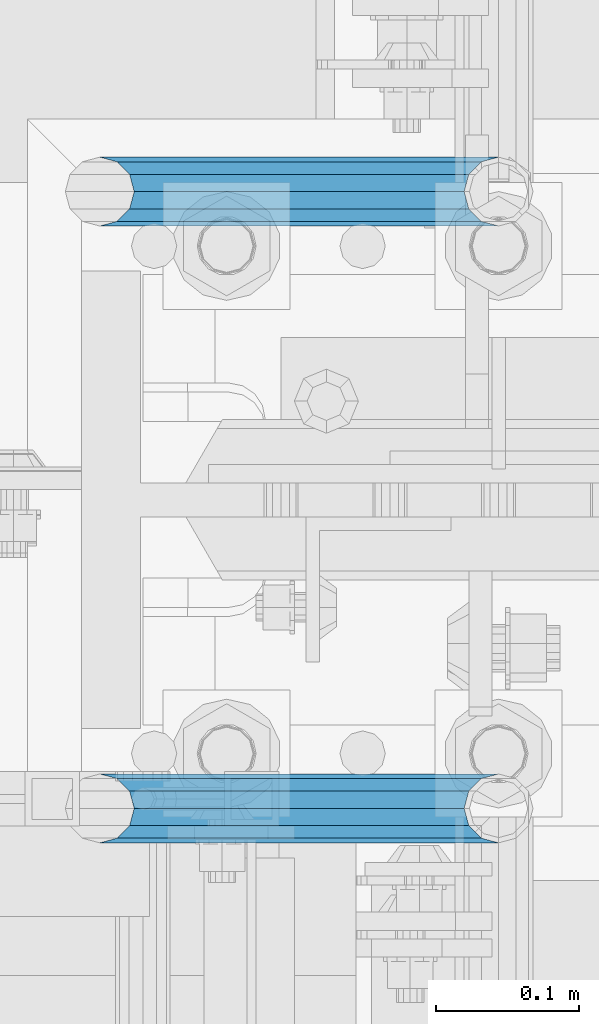
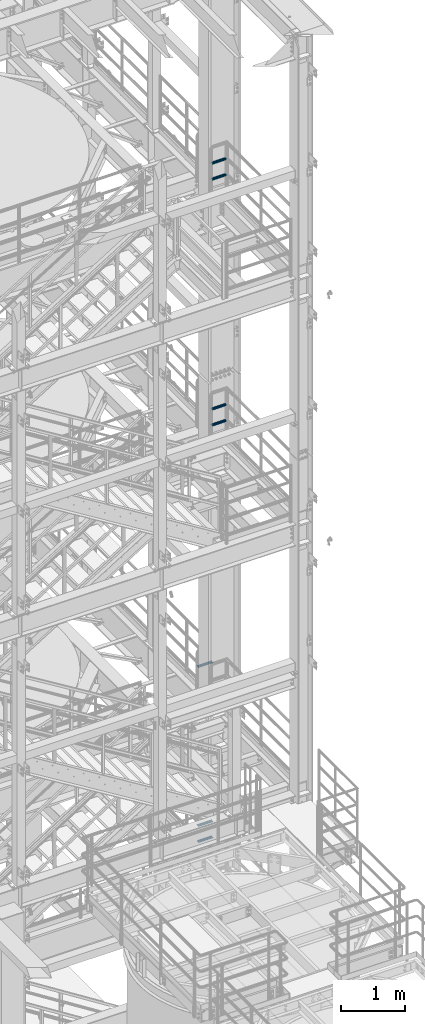
# One storey, part 1209 of 1876: 7 beams, 4 elements without a shape of their own.
"""IFC2X3 building model written with IfcOpenShell, lengths in millimetres."""

from ifc_helpers import new_model, si_unit, frame, origin_with_axes, place, context, subcontext, project, spatial, faceted_brep, material, type_object, element, aggregate, save


model = new_model("IFC2X3")

# Units and contexts
model_context = context("Model", 3, precision=1e-05, world=origin_with_axes())
body_context = subcontext(model_context, "Body", "Model", "MODEL_VIEW")
ifc_project = project(units=[si_unit("LENGTHUNIT", "METRE", prefix="MILLI"), si_unit("AREAUNIT", "SQUARE_METRE"), si_unit("VOLUMEUNIT", "CUBIC_METRE"), si_unit("MASSUNIT", "GRAM", prefix="KILO"), si_unit("TIMEUNIT", "SECOND"), si_unit("PLANEANGLEUNIT", "RADIAN"), si_unit("SOLIDANGLEUNIT", "STERADIAN"), si_unit("THERMODYNAMICTEMPERATUREUNIT", "DEGREE_CELSIUS"), si_unit("LUMINOUSINTENSITYUNIT", "LUMEN")], contexts=[model_context])

# Site, building, storey
site_placement = place(None, origin_with_axes())
site = spatial("IfcSite", under=ifc_project, at=site_placement, CompositionType="ELEMENT")
building_placement = place(site_placement, origin_with_axes())
building = spatial("IfcBuilding", under=site, at=building_placement, Name="Undefined", CompositionType="ELEMENT")
storey_placement = place(building_placement, origin_with_axes())
storey = spatial("IfcBuildingStorey", under=building, at=storey_placement, Name="Undefined", CompositionType="ELEMENT", Elevation=0.0)

# Assembly, beam
assembly_1_placement = place(storey_placement, origin_with_axes())
assembly_1 = element("IfcElementAssembly", 1, at=assembly_1_placement, inside=storey, Name="RAIL", AssemblyPlace="NOTDEFINED", PredefinedType="RIGID_FRAME")
ifc_material = material()
beam_type = type_object("IfcBeamType", Name="PIPE1-1/2SCH40", PredefinedType="NOTDEFINED")
beam_1_placement = place(assembly_1_placement, frame((7620.00000000001, -4356.1, 8924.92500003594), z_axis=(0.0, 0.0, 1.0), x_axis=(-1.0, 0.0, 0.0)))
beam_1 = element("IfcBeam", 2, at=beam_1_placement, type_object=beam_type, material=ifc_material, Name="RAIL", ObjectType="PIPE1-1/2SCH40", context=body_context, shape_type="Brep", body=[
    faceted_brep([(258.502800903171, -12.0650000000005, 20.8971929933177), (258.502800903171, -12.0650000000005, 15.8661214311796), (258.009372465309, -10.2235000000001, 17.7076214311819), (255.26999389649, 0.0, 20.4470000000001), (255.26999389649, 0.0, 24.130000000001), (258.009372465309, 10.2235000000001, 17.7076214311819), (258.502800903171, 12.0650000000005, 15.8661214311796), (258.502800903171, 12.0650000000005, 20.8971929933177), (279.399993896489, 24.1299999999992, 0.0), (267.33499389649, 20.8971929933177, 12.0649999999987), (267.33499389649, 20.8971929933177, -12.0649999999987), (264.145422334351, 17.7076214311801, 10.2235000000001), (266.884800903171, 20.4470000000001, 0.0), (264.145422334351, 17.7076214311801, -10.2235000000001), (258.502800903171, 12.0650000000005, -15.8661214311796), (258.502800903171, 12.0650000000005, -20.8971929933177), (258.009372465309, 10.2235000000001, -17.7076214311819), (255.26999389649, 0.0, -20.4470000000001), (255.26999389649, 0.0, -24.130000000001), (258.502800903171, -12.0650000000005, -15.8661214311796), (258.502800903171, -12.0650000000005, -20.8971929933177), (258.009372465309, -10.2235000000001, -17.7076214311819), (279.399993896489, -24.1299999999992, 0.0), (267.33499389649, -20.8971929933177, -12.0649999999987), (267.33499389649, -20.8971929933177, 12.0649999999987), (264.145422334351, -17.7076214311801, -10.2235000000001), (266.884800903171, -20.4470000000001, 0.0), (264.145422334351, -17.7076214311801, 10.2235000000001), (12.0650000000064, -20.8971929933177, -12.0649999999987), (20.8971929933249, -12.0650000000005, -20.8971929933177), (0.0, 24.1299999999992, 0.0), (12.0650000000064, 20.8971929933177, -12.0649999999987), (12.0650000000064, 20.8971929933177, 12.0649999999987), (20.8971929933249, 12.0650000000005, 20.8971929933177), (24.1300000000064, 0.0, 24.130000000001), (20.8971929933249, 12.0650000000005, -20.8971929933177), (24.1300000000063, 0.0, -24.130000000001), (24.1300000000063, 0.0, -20.4470000000001), (20.8971929933249, -12.0650000000005, -15.8661214311796), (21.3906214311868, -10.2235000000001, -17.7076214311819), (21.3906214311868, 10.2235000000001, -17.7076214311819), (20.8971929933249, 12.0650000000005, -15.8661214311796), (15.2545715621445, 17.7076214311801, -10.2235000000001), (12.5151929933249, 20.4470000000001, 0.0), (15.2545715621445, 17.7076214311801, 10.2235000000001), (20.8971929933249, 12.0650000000005, 15.8661214311796), (21.3906214311868, 10.2235000000001, 17.7076214311819), (24.1300000000064, 0.0, 20.4470000000001), (21.3906214311868, -10.2235000000001, 17.7076214311819), (20.8971929933249, -12.0650000000005, 15.8661214311796), (20.8971929933249, -12.0650000000005, 20.8971929933177), (12.0650000000064, -20.8971929933177, 12.0649999999987), (0.0, -24.1299999999992, 0.0), (15.2545715621445, -17.7076214311801, 10.2235000000001), (12.5151929933249, -20.4470000000001, 0.0), (15.2545715621445, -17.7076214311801, -10.2235000000001)], [[[0, 1, 2, 3, 4]], [[4, 3, 5, 6, 7]], [[8, 9, 10]], [[7, 6, 11, 12, 13, 14, 15, 10, 9]], [[16, 17, 18, 15, 14]], [[19, 20, 18, 17, 21]], [[22, 23, 24]], [[24, 23, 20, 19, 25, 26, 27, 1, 0]], [[28, 29, 20, 23]], [[30, 31, 32]], [[33, 34, 4, 7]], [[32, 33, 7, 9]], [[30, 32, 9, 8]], [[31, 30, 8, 10]], [[35, 31, 10, 15]], [[36, 35, 15, 18]], [[29, 36, 18, 20]], [[37, 36, 29, 38, 39]], [[40, 41, 35, 36, 37]], [[32, 31, 35, 41, 42, 43, 44, 45, 33]], [[33, 45, 46, 47, 34]], [[34, 47, 48, 49, 50]], [[34, 50, 0, 4]], [[50, 51, 24, 0]], [[51, 52, 22, 24]], [[52, 28, 23, 22]], [[51, 28, 52]], [[50, 49, 53, 54, 55, 38, 29, 28, 51]], [[55, 54, 26, 25]], [[21, 39, 38, 55, 25, 19]], [[37, 39, 21, 17]], [[40, 37, 17, 16]], [[42, 41, 40, 16, 14, 13]], [[43, 42, 13, 12]], [[44, 43, 12, 11]], [[5, 46, 45, 44, 11, 6]], [[47, 46, 5, 3]], [[48, 47, 3, 2]], [[53, 49, 48, 2, 1, 27]], [[54, 53, 27, 26]]]),
])
aggregate(assembly_1, [beam_1])

# Assembly, beams
assembly_2_placement = place(storey_placement, origin_with_axes())
assembly_2 = element("IfcElementAssembly", 3, at=assembly_2_placement, inside=storey, Name="RAIL", AssemblyPlace="NOTDEFINED", PredefinedType="RIGID_FRAME")
beam_2_placement = place(assembly_2_placement, frame((7620.00000000001, -4356.1, 5597.525000036), z_axis=(0.0, 0.0, 1.0), x_axis=(-1.0, 0.0, 0.0)))
beam_2 = element("IfcBeam", 4, at=beam_2_placement, type_object=beam_type, material=ifc_material, Name="RAIL", ObjectType="PIPE1-1/2SCH40", context=body_context, shape_type="Brep", body=[
    faceted_brep([(258.502800903171, -12.0650000000005, 20.8971929933177), (258.502800903171, -12.0650000000005, 15.8661214311796), (258.009372465309, -10.2235000000001, 17.7076214311819), (255.26999389649, 0.0, 20.4470000000001), (255.26999389649, 0.0, 24.130000000001), (258.009372465309, 10.2235000000001, 17.7076214311819), (258.502800903171, 12.0650000000005, 15.8661214311796), (258.502800903171, 12.0650000000005, 20.8971929933177), (279.399993896489, 24.1299999999992, 0.0), (267.33499389649, 20.8971929933177, 12.0649999999987), (267.33499389649, 20.8971929933177, -12.0649999999987), (264.145422334351, 17.7076214311801, 10.2235000000001), (266.884800903171, 20.4470000000001, 0.0), (264.145422334351, 17.7076214311801, -10.2235000000001), (258.502800903171, 12.0650000000005, -15.8661214311796), (258.502800903171, 12.0650000000005, -20.8971929933177), (258.009372465309, 10.2235000000001, -17.7076214311819), (255.26999389649, 0.0, -20.4470000000001), (255.26999389649, 0.0, -24.130000000001), (258.502800903171, -12.0650000000005, -15.8661214311796), (258.502800903171, -12.0650000000005, -20.8971929933177), (258.009372465309, -10.2235000000001, -17.7076214311819), (279.399993896489, -24.1299999999992, 0.0), (267.33499389649, -20.8971929933177, -12.0649999999987), (267.33499389649, -20.8971929933177, 12.0649999999987), (264.145422334351, -17.7076214311801, -10.2235000000001), (266.884800903171, -20.4470000000001, 0.0), (264.145422334351, -17.7076214311801, 10.2235000000001), (12.0650000000064, -20.8971929933177, -12.0649999999987), (20.8971929933249, -12.0650000000005, -20.8971929933177), (0.0, 24.1299999999992, 0.0), (12.0650000000064, 20.8971929933177, -12.0649999999987), (12.0650000000064, 20.8971929933177, 12.0649999999987), (20.8971929933249, 12.0650000000005, 20.8971929933177), (24.1300000000064, 0.0, 24.130000000001), (20.8971929933249, 12.0650000000005, -20.8971929933177), (24.1300000000063, 0.0, -24.130000000001), (24.1300000000063, 0.0, -20.4470000000001), (20.8971929933249, -12.0650000000005, -15.8661214311796), (21.3906214311868, -10.2235000000001, -17.7076214311819), (21.3906214311868, 10.2235000000001, -17.7076214311819), (20.8971929933249, 12.0650000000005, -15.8661214311796), (15.2545715621445, 17.7076214311801, -10.2235000000001), (12.5151929933249, 20.4470000000001, 0.0), (15.2545715621445, 17.7076214311801, 10.2235000000001), (20.8971929933249, 12.0650000000005, 15.8661214311796), (21.3906214311868, 10.2235000000001, 17.7076214311819), (24.1300000000064, 0.0, 20.4470000000001), (21.3906214311868, -10.2235000000001, 17.7076214311819), (20.8971929933249, -12.0650000000005, 15.8661214311796), (20.8971929933249, -12.0650000000005, 20.8971929933177), (12.0650000000064, -20.8971929933177, 12.0649999999987), (0.0, -24.1299999999992, 0.0), (15.2545715621445, -17.7076214311801, 10.2235000000001), (12.5151929933249, -20.4470000000001, 0.0), (15.2545715621445, -17.7076214311801, -10.2235000000001)], [[[0, 1, 2, 3, 4]], [[4, 3, 5, 6, 7]], [[8, 9, 10]], [[7, 6, 11, 12, 13, 14, 15, 10, 9]], [[16, 17, 18, 15, 14]], [[19, 20, 18, 17, 21]], [[22, 23, 24]], [[24, 23, 20, 19, 25, 26, 27, 1, 0]], [[28, 29, 20, 23]], [[30, 31, 32]], [[33, 34, 4, 7]], [[32, 33, 7, 9]], [[30, 32, 9, 8]], [[31, 30, 8, 10]], [[35, 31, 10, 15]], [[36, 35, 15, 18]], [[29, 36, 18, 20]], [[37, 36, 29, 38, 39]], [[40, 41, 35, 36, 37]], [[32, 31, 35, 41, 42, 43, 44, 45, 33]], [[33, 45, 46, 47, 34]], [[34, 47, 48, 49, 50]], [[34, 50, 0, 4]], [[50, 51, 24, 0]], [[51, 52, 22, 24]], [[52, 28, 23, 22]], [[51, 28, 52]], [[50, 49, 53, 54, 55, 38, 29, 28, 51]], [[55, 54, 26, 25]], [[21, 39, 38, 55, 25, 19]], [[37, 39, 21, 17]], [[40, 37, 17, 16]], [[42, 41, 40, 16, 14, 13]], [[43, 42, 13, 12]], [[44, 43, 12, 11]], [[5, 46, 45, 44, 11, 6]], [[47, 46, 5, 3]], [[48, 47, 3, 2]], [[53, 49, 48, 2, 1, 27]], [[54, 53, 27, 26]]]),
])
beam_3_placement = place(assembly_2_placement, frame((7620.00000000001, -4356.1, 5902.32500003594), z_axis=(0.0, 0.0, 1.0), x_axis=(-1.0, 0.0, 0.0)))
beam_3 = element("IfcBeam", 5, at=beam_3_placement, type_object=beam_type, material=ifc_material, Name="RAIL", ObjectType="PIPE1-1/2SCH40", context=body_context, shape_type="Brep", body=[
    faceted_brep([(258.502800903171, -12.0650000000005, 20.8971929933177), (258.502800903171, -12.0650000000005, 15.8661214311796), (258.009372465309, -10.2235000000001, 17.7076214311819), (255.26999389649, 0.0, 20.4470000000001), (255.26999389649, 0.0, 24.130000000001), (258.009372465309, 10.2235000000001, 17.7076214311819), (258.502800903171, 12.0650000000005, 15.8661214311796), (258.502800903171, 12.0650000000005, 20.8971929933177), (279.399993896489, 24.1299999999992, 0.0), (267.33499389649, 20.8971929933177, 12.0649999999987), (267.33499389649, 20.8971929933177, -12.0649999999987), (264.145422334351, 17.7076214311801, 10.2235000000001), (266.884800903171, 20.4470000000001, 0.0), (264.145422334351, 17.7076214311801, -10.2235000000001), (258.502800903171, 12.0650000000005, -15.8661214311796), (258.502800903171, 12.0650000000005, -20.8971929933177), (258.009372465309, 10.2235000000001, -17.7076214311819), (255.26999389649, 0.0, -20.4470000000001), (255.26999389649, 0.0, -24.130000000001), (258.502800903171, -12.0650000000005, -15.8661214311796), (258.502800903171, -12.0650000000005, -20.8971929933177), (258.009372465309, -10.2235000000001, -17.7076214311819), (279.399993896489, -24.1299999999992, 0.0), (267.33499389649, -20.8971929933177, -12.0649999999987), (267.33499389649, -20.8971929933177, 12.0649999999987), (264.145422334351, -17.7076214311801, -10.2235000000001), (266.884800903171, -20.4470000000001, 0.0), (264.145422334351, -17.7076214311801, 10.2235000000001), (12.0650000000064, -20.8971929933177, -12.0649999999987), (20.8971929933249, -12.0650000000005, -20.8971929933177), (0.0, 24.1299999999992, 0.0), (12.0650000000064, 20.8971929933177, -12.0649999999987), (12.0650000000064, 20.8971929933177, 12.0649999999987), (20.8971929933249, 12.0650000000005, 20.8971929933177), (24.1300000000064, 0.0, 24.130000000001), (20.8971929933249, 12.0650000000005, -20.8971929933177), (24.1300000000063, 0.0, -24.130000000001), (24.1300000000063, 0.0, -20.4470000000001), (20.8971929933249, -12.0650000000005, -15.8661214311796), (21.3906214311868, -10.2235000000001, -17.7076214311819), (21.3906214311868, 10.2235000000001, -17.7076214311819), (20.8971929933249, 12.0650000000005, -15.8661214311796), (15.2545715621445, 17.7076214311801, -10.2235000000001), (12.5151929933249, 20.4470000000001, 0.0), (15.2545715621445, 17.7076214311801, 10.2235000000001), (20.8971929933249, 12.0650000000005, 15.8661214311796), (21.3906214311868, 10.2235000000001, 17.7076214311819), (24.1300000000064, 0.0, 20.4470000000001), (21.3906214311868, -10.2235000000001, 17.7076214311819), (20.8971929933249, -12.0650000000005, 15.8661214311796), (20.8971929933249, -12.0650000000005, 20.8971929933177), (12.0650000000064, -20.8971929933177, 12.0649999999987), (0.0, -24.1299999999992, 0.0), (15.2545715621445, -17.7076214311801, 10.2235000000001), (12.5151929933249, -20.4470000000001, 0.0), (15.2545715621445, -17.7076214311801, -10.2235000000001)], [[[0, 1, 2, 3, 4]], [[4, 3, 5, 6, 7]], [[8, 9, 10]], [[7, 6, 11, 12, 13, 14, 15, 10, 9]], [[16, 17, 18, 15, 14]], [[19, 20, 18, 17, 21]], [[22, 23, 24]], [[24, 23, 20, 19, 25, 26, 27, 1, 0]], [[28, 29, 20, 23]], [[30, 31, 32]], [[33, 34, 4, 7]], [[32, 33, 7, 9]], [[30, 32, 9, 8]], [[31, 30, 8, 10]], [[35, 31, 10, 15]], [[36, 35, 15, 18]], [[29, 36, 18, 20]], [[37, 36, 29, 38, 39]], [[40, 41, 35, 36, 37]], [[32, 31, 35, 41, 42, 43, 44, 45, 33]], [[33, 45, 46, 47, 34]], [[34, 47, 48, 49, 50]], [[34, 50, 0, 4]], [[50, 51, 24, 0]], [[51, 52, 22, 24]], [[52, 28, 23, 22]], [[51, 28, 52]], [[50, 49, 53, 54, 55, 38, 29, 28, 51]], [[55, 54, 26, 25]], [[21, 39, 38, 55, 25, 19]], [[37, 39, 21, 17]], [[40, 37, 17, 16]], [[42, 41, 40, 16, 14, 13]], [[43, 42, 13, 12]], [[44, 43, 12, 11]], [[5, 46, 45, 44, 11, 6]], [[47, 46, 5, 3]], [[48, 47, 3, 2]], [[53, 49, 48, 2, 1, 27]], [[54, 53, 27, 26]]]),
])
aggregate(assembly_2, [beam_2, beam_3])

assembly_3_placement = place(storey_placement, origin_with_axes())
assembly_3 = element("IfcElementAssembly", 6, at=assembly_3_placement, inside=storey, Name="RAIL", AssemblyPlace="NOTDEFINED", PredefinedType="RIGID_FRAME")
beam_4_placement = place(assembly_3_placement, frame((7620.0, -4788.2175, 18449.925000036), z_axis=(0.0, 0.0, 1.0), x_axis=(-1.0, 0.0, 0.0)))
beam_4 = element("IfcBeam", 7, at=beam_4_placement, type_object=beam_type, material=ifc_material, Name="RAIL", ObjectType="PIPE1-1/2SCH40", context=body_context, shape_type="Brep", body=[
    faceted_brep([(258.502800903171, -12.0650000000005, 20.8971929933177), (258.502800903171, -12.0650000000005, 15.8661214311796), (258.009372465309, -10.2235000000001, 17.7076214311819), (255.26999389649, 0.0, 20.4470000000001), (255.26999389649, 0.0, 24.130000000001), (258.009372465309, 10.2235000000001, 17.7076214311819), (258.502800903171, 12.0650000000005, 15.8661214311796), (258.502800903171, 12.0650000000005, 20.8971929933177), (279.399993896489, 24.1299999999992, 0.0), (267.33499389649, 20.8971929933177, 12.0649999999987), (267.33499389649, 20.8971929933177, -12.0649999999987), (264.145422334351, 17.7076214311801, 10.2235000000001), (266.884800903171, 20.4470000000001, 0.0), (264.145422334351, 17.7076214311801, -10.2235000000001), (258.502800903171, 12.0650000000005, -15.8661214311796), (258.502800903171, 12.0650000000005, -20.8971929933177), (258.009372465309, 10.2235000000001, -17.7076214311819), (255.26999389649, 0.0, -20.4470000000001), (255.26999389649, 0.0, -24.130000000001), (258.502800903171, -12.0650000000005, -15.8661214311796), (258.502800903171, -12.0650000000005, -20.8971929933177), (258.009372465309, -10.2235000000001, -17.7076214311819), (279.399993896489, -24.1299999999992, 0.0), (267.33499389649, -20.8971929933177, -12.0649999999987), (267.33499389649, -20.8971929933177, 12.0649999999987), (264.145422334351, -17.7076214311801, -10.2235000000001), (266.884800903171, -20.4470000000001, 0.0), (264.145422334351, -17.7076214311801, 10.2235000000001), (12.0650000000064, -20.8971929933177, -12.0649999999987), (20.8971929933249, -12.0650000000005, -20.8971929933177), (0.0, 24.1299999999992, 0.0), (12.0650000000064, 20.8971929933177, -12.0649999999987), (12.0650000000064, 20.8971929933177, 12.0649999999987), (20.8971929933249, 12.0650000000005, 20.8971929933177), (24.1300000000064, 0.0, 24.130000000001), (20.8971929933249, 12.0650000000005, -20.8971929933177), (24.1300000000063, 0.0, -24.130000000001), (24.1300000000063, 0.0, -20.4470000000001), (20.8971929933249, -12.0650000000005, -15.8661214311796), (21.3906214311868, -10.2235000000001, -17.7076214311819), (21.3906214311868, 10.2235000000001, -17.7076214311819), (20.8971929933249, 12.0650000000005, -15.8661214311796), (15.2545715621445, 17.7076214311801, -10.2235000000001), (12.5151929933249, 20.4470000000001, 0.0), (15.2545715621445, 17.7076214311801, 10.2235000000001), (20.8971929933249, 12.0650000000005, 15.8661214311796), (21.3906214311868, 10.2235000000001, 17.7076214311819), (24.1300000000064, 0.0, 20.4470000000001), (21.3906214311868, -10.2235000000001, 17.7076214311819), (20.8971929933249, -12.0650000000005, 15.8661214311796), (20.8971929933249, -12.0650000000005, 20.8971929933177), (12.0650000000064, -20.8971929933177, 12.0649999999987), (0.0, -24.1299999999992, 0.0), (15.2545715621445, -17.7076214311801, 10.2235000000001), (12.5151929933249, -20.4470000000001, 0.0), (15.2545715621445, -17.7076214311801, -10.2235000000001)], [[[0, 1, 2, 3, 4]], [[4, 3, 5, 6, 7]], [[8, 9, 10]], [[7, 6, 11, 12, 13, 14, 15, 10, 9]], [[16, 17, 18, 15, 14]], [[19, 20, 18, 17, 21]], [[22, 23, 24]], [[24, 23, 20, 19, 25, 26, 27, 1, 0]], [[28, 29, 20, 23]], [[30, 31, 32]], [[33, 34, 4, 7]], [[32, 33, 7, 9]], [[30, 32, 9, 8]], [[31, 30, 8, 10]], [[35, 31, 10, 15]], [[36, 35, 15, 18]], [[29, 36, 18, 20]], [[37, 36, 29, 38, 39]], [[40, 41, 35, 36, 37]], [[32, 31, 35, 41, 42, 43, 44, 45, 33]], [[33, 45, 46, 47, 34]], [[34, 47, 48, 49, 50]], [[34, 50, 0, 4]], [[50, 51, 24, 0]], [[51, 52, 22, 24]], [[52, 28, 23, 22]], [[51, 28, 52]], [[50, 49, 53, 54, 55, 38, 29, 28, 51]], [[55, 54, 26, 25]], [[21, 39, 38, 55, 25, 19]], [[37, 39, 21, 17]], [[40, 37, 17, 16]], [[42, 41, 40, 16, 14, 13]], [[43, 42, 13, 12]], [[44, 43, 12, 11]], [[5, 46, 45, 44, 11, 6]], [[47, 46, 5, 3]], [[48, 47, 3, 2]], [[53, 49, 48, 2, 1, 27]], [[54, 53, 27, 26]]]),
])
beam_5_placement = place(assembly_3_placement, frame((7620.0, -4788.2175, 18754.7250000359), z_axis=(0.0, 0.0, 1.0), x_axis=(-1.0, 0.0, 0.0)))
beam_5 = element("IfcBeam", 8, at=beam_5_placement, type_object=beam_type, material=ifc_material, Name="RAIL", ObjectType="PIPE1-1/2SCH40", context=body_context, shape_type="Brep", body=[
    faceted_brep([(258.502800903171, -12.0650000000005, 20.8971929933177), (258.502800903171, -12.0650000000005, 15.8661214311796), (258.009372465309, -10.2235000000001, 17.7076214311819), (255.26999389649, 0.0, 20.4470000000001), (255.26999389649, 0.0, 24.130000000001), (258.009372465309, 10.2235000000001, 17.7076214311819), (258.502800903171, 12.0650000000005, 15.8661214311796), (258.502800903171, 12.0650000000005, 20.8971929933177), (279.399993896489, 24.1299999999992, 0.0), (267.33499389649, 20.8971929933177, 12.0649999999987), (267.33499389649, 20.8971929933177, -12.0649999999987), (264.145422334351, 17.7076214311801, 10.2235000000001), (266.884800903171, 20.4470000000001, 0.0), (264.145422334351, 17.7076214311801, -10.2235000000001), (258.502800903171, 12.0650000000005, -15.8661214311796), (258.502800903171, 12.0650000000005, -20.8971929933177), (258.009372465309, 10.2235000000001, -17.7076214311819), (255.26999389649, 0.0, -20.4470000000001), (255.26999389649, 0.0, -24.130000000001), (258.502800903171, -12.0650000000005, -15.8661214311796), (258.502800903171, -12.0650000000005, -20.8971929933177), (258.009372465309, -10.2235000000001, -17.7076214311819), (279.399993896489, -24.1299999999992, 0.0), (267.33499389649, -20.8971929933177, -12.0649999999987), (267.33499389649, -20.8971929933177, 12.0649999999987), (264.145422334351, -17.7076214311801, -10.2235000000001), (266.884800903171, -20.4470000000001, 0.0), (264.145422334351, -17.7076214311801, 10.2235000000001), (12.0650000000064, -20.8971929933177, -12.0649999999987), (20.8971929933249, -12.0650000000005, -20.8971929933177), (0.0, 24.1299999999992, 0.0), (12.0650000000064, 20.8971929933177, -12.0649999999987), (12.0650000000064, 20.8971929933177, 12.0649999999987), (20.8971929933249, 12.0650000000005, 20.8971929933177), (24.1300000000064, 0.0, 24.130000000001), (20.8971929933249, 12.0650000000005, -20.8971929933177), (24.1300000000063, 0.0, -24.130000000001), (24.1300000000063, 0.0, -20.4470000000001), (20.8971929933249, -12.0650000000005, -15.8661214311796), (21.3906214311868, -10.2235000000001, -17.7076214311819), (21.3906214311868, 10.2235000000001, -17.7076214311819), (20.8971929933249, 12.0650000000005, -15.8661214311796), (15.2545715621445, 17.7076214311801, -10.2235000000001), (12.5151929933249, 20.4470000000001, 0.0), (15.2545715621445, 17.7076214311801, 10.2235000000001), (20.8971929933249, 12.0650000000005, 15.8661214311796), (21.3906214311868, 10.2235000000001, 17.7076214311819), (24.1300000000064, 0.0, 20.4470000000001), (21.3906214311868, -10.2235000000001, 17.7076214311819), (20.8971929933249, -12.0650000000005, 15.8661214311796), (20.8971929933249, -12.0650000000005, 20.8971929933177), (12.0650000000064, -20.8971929933177, 12.0649999999987), (0.0, -24.1299999999992, 0.0), (15.2545715621445, -17.7076214311801, 10.2235000000001), (12.5151929933249, -20.4470000000001, 0.0), (15.2545715621445, -17.7076214311801, -10.2235000000001)], [[[0, 1, 2, 3, 4]], [[4, 3, 5, 6, 7]], [[8, 9, 10]], [[7, 6, 11, 12, 13, 14, 15, 10, 9]], [[16, 17, 18, 15, 14]], [[19, 20, 18, 17, 21]], [[22, 23, 24]], [[24, 23, 20, 19, 25, 26, 27, 1, 0]], [[28, 29, 20, 23]], [[30, 31, 32]], [[33, 34, 4, 7]], [[32, 33, 7, 9]], [[30, 32, 9, 8]], [[31, 30, 8, 10]], [[35, 31, 10, 15]], [[36, 35, 15, 18]], [[29, 36, 18, 20]], [[37, 36, 29, 38, 39]], [[40, 41, 35, 36, 37]], [[32, 31, 35, 41, 42, 43, 44, 45, 33]], [[33, 45, 46, 47, 34]], [[34, 47, 48, 49, 50]], [[34, 50, 0, 4]], [[50, 51, 24, 0]], [[51, 52, 22, 24]], [[52, 28, 23, 22]], [[51, 28, 52]], [[50, 49, 53, 54, 55, 38, 29, 28, 51]], [[55, 54, 26, 25]], [[21, 39, 38, 55, 25, 19]], [[37, 39, 21, 17]], [[40, 37, 17, 16]], [[42, 41, 40, 16, 14, 13]], [[43, 42, 13, 12]], [[44, 43, 12, 11]], [[5, 46, 45, 44, 11, 6]], [[47, 46, 5, 3]], [[48, 47, 3, 2]], [[53, 49, 48, 2, 1, 27]], [[54, 53, 27, 26]]]),
])
aggregate(assembly_3, [beam_4, beam_5])

assembly_4_placement = place(storey_placement, origin_with_axes())
assembly_4 = element("IfcElementAssembly", 9, at=assembly_4_placement, inside=storey, Name="RAIL", AssemblyPlace="NOTDEFINED", PredefinedType="RIGID_FRAME")
beam_6_placement = place(assembly_4_placement, frame((7620.0, -4788.2175, 13776.325000036), z_axis=(0.0, 0.0, 1.0), x_axis=(-1.0, 0.0, 0.0)))
beam_6 = element("IfcBeam", 10, at=beam_6_placement, type_object=beam_type, material=ifc_material, Name="RAIL", ObjectType="PIPE1-1/2SCH40", context=body_context, shape_type="Brep", body=[
    faceted_brep([(258.502800903171, -12.0650000000005, 20.8971929933177), (258.502800903171, -12.0650000000005, 15.8661214311796), (258.009372465309, -10.2235000000001, 17.7076214311819), (255.26999389649, 0.0, 20.4470000000001), (255.26999389649, 0.0, 24.130000000001), (258.009372465309, 10.2235000000001, 17.7076214311819), (258.502800903171, 12.0650000000005, 15.8661214311796), (258.502800903171, 12.0650000000005, 20.8971929933177), (279.399993896489, 24.1299999999992, 0.0), (267.33499389649, 20.8971929933177, 12.0649999999987), (267.33499389649, 20.8971929933177, -12.0649999999987), (264.145422334351, 17.7076214311801, 10.2235000000001), (266.884800903171, 20.4470000000001, 0.0), (264.145422334351, 17.7076214311801, -10.2235000000001), (258.502800903171, 12.0650000000005, -15.8661214311796), (258.502800903171, 12.0650000000005, -20.8971929933177), (258.009372465309, 10.2235000000001, -17.7076214311819), (255.26999389649, 0.0, -20.4470000000001), (255.26999389649, 0.0, -24.130000000001), (258.502800903171, -12.0650000000005, -15.8661214311796), (258.502800903171, -12.0650000000005, -20.8971929933177), (258.009372465309, -10.2235000000001, -17.7076214311819), (279.399993896489, -24.1299999999992, 0.0), (267.33499389649, -20.8971929933177, -12.0649999999987), (267.33499389649, -20.8971929933177, 12.0649999999987), (264.145422334351, -17.7076214311801, -10.2235000000001), (266.884800903171, -20.4470000000001, 0.0), (264.145422334351, -17.7076214311801, 10.2235000000001), (12.0650000000064, -20.8971929933177, -12.0649999999987), (20.8971929933249, -12.0650000000005, -20.8971929933177), (0.0, 24.1299999999992, 0.0), (12.0650000000064, 20.8971929933177, -12.0649999999987), (12.0650000000064, 20.8971929933177, 12.0649999999987), (20.8971929933249, 12.0650000000005, 20.8971929933177), (24.1300000000064, 0.0, 24.130000000001), (20.8971929933249, 12.0650000000005, -20.8971929933177), (24.1300000000063, 0.0, -24.130000000001), (24.1300000000063, 0.0, -20.4470000000001), (20.8971929933249, -12.0650000000005, -15.8661214311796), (21.3906214311868, -10.2235000000001, -17.7076214311819), (21.3906214311868, 10.2235000000001, -17.7076214311819), (20.8971929933249, 12.0650000000005, -15.8661214311796), (15.2545715621445, 17.7076214311801, -10.2235000000001), (12.5151929933249, 20.4470000000001, 0.0), (15.2545715621445, 17.7076214311801, 10.2235000000001), (20.8971929933249, 12.0650000000005, 15.8661214311796), (21.3906214311868, 10.2235000000001, 17.7076214311819), (24.1300000000064, 0.0, 20.4470000000001), (21.3906214311868, -10.2235000000001, 17.7076214311819), (20.8971929933249, -12.0650000000005, 15.8661214311796), (20.8971929933249, -12.0650000000005, 20.8971929933177), (12.0650000000064, -20.8971929933177, 12.0649999999987), (0.0, -24.1299999999992, 0.0), (15.2545715621445, -17.7076214311801, 10.2235000000001), (12.5151929933249, -20.4470000000001, 0.0), (15.2545715621445, -17.7076214311801, -10.2235000000001)], [[[0, 1, 2, 3, 4]], [[4, 3, 5, 6, 7]], [[8, 9, 10]], [[7, 6, 11, 12, 13, 14, 15, 10, 9]], [[16, 17, 18, 15, 14]], [[19, 20, 18, 17, 21]], [[22, 23, 24]], [[24, 23, 20, 19, 25, 26, 27, 1, 0]], [[28, 29, 20, 23]], [[30, 31, 32]], [[33, 34, 4, 7]], [[32, 33, 7, 9]], [[30, 32, 9, 8]], [[31, 30, 8, 10]], [[35, 31, 10, 15]], [[36, 35, 15, 18]], [[29, 36, 18, 20]], [[37, 36, 29, 38, 39]], [[40, 41, 35, 36, 37]], [[32, 31, 35, 41, 42, 43, 44, 45, 33]], [[33, 45, 46, 47, 34]], [[34, 47, 48, 49, 50]], [[34, 50, 0, 4]], [[50, 51, 24, 0]], [[51, 52, 22, 24]], [[52, 28, 23, 22]], [[51, 28, 52]], [[50, 49, 53, 54, 55, 38, 29, 28, 51]], [[55, 54, 26, 25]], [[21, 39, 38, 55, 25, 19]], [[37, 39, 21, 17]], [[40, 37, 17, 16]], [[42, 41, 40, 16, 14, 13]], [[43, 42, 13, 12]], [[44, 43, 12, 11]], [[5, 46, 45, 44, 11, 6]], [[47, 46, 5, 3]], [[48, 47, 3, 2]], [[53, 49, 48, 2, 1, 27]], [[54, 53, 27, 26]]]),
])
beam_7_placement = place(assembly_4_placement, frame((7620.0, -4788.2175, 14081.1250000359), z_axis=(0.0, 0.0, 1.0), x_axis=(-1.0, 0.0, 0.0)))
beam_7 = element("IfcBeam", 11, at=beam_7_placement, type_object=beam_type, material=ifc_material, Name="RAIL", ObjectType="PIPE1-1/2SCH40", context=body_context, shape_type="Brep", body=[
    faceted_brep([(258.502800903171, -12.0650000000005, 20.8971929933177), (258.502800903171, -12.0650000000005, 15.8661214311796), (258.009372465309, -10.2235000000001, 17.7076214311819), (255.26999389649, 0.0, 20.4470000000001), (255.26999389649, 0.0, 24.130000000001), (258.009372465309, 10.2235000000001, 17.7076214311819), (258.502800903171, 12.0650000000005, 15.8661214311796), (258.502800903171, 12.0650000000005, 20.8971929933177), (279.399993896489, 24.1299999999992, 0.0), (267.33499389649, 20.8971929933177, 12.0649999999987), (267.33499389649, 20.8971929933177, -12.0649999999987), (264.145422334351, 17.7076214311801, 10.2235000000001), (266.884800903171, 20.4470000000001, 0.0), (264.145422334351, 17.7076214311801, -10.2235000000001), (258.502800903171, 12.0650000000005, -15.8661214311796), (258.502800903171, 12.0650000000005, -20.8971929933177), (258.009372465309, 10.2235000000001, -17.7076214311819), (255.26999389649, 0.0, -20.4470000000001), (255.26999389649, 0.0, -24.130000000001), (258.502800903171, -12.0650000000005, -15.8661214311796), (258.502800903171, -12.0650000000005, -20.8971929933177), (258.009372465309, -10.2235000000001, -17.7076214311819), (279.399993896489, -24.1299999999992, 0.0), (267.33499389649, -20.8971929933177, -12.0649999999987), (267.33499389649, -20.8971929933177, 12.0649999999987), (264.145422334351, -17.7076214311801, -10.2235000000001), (266.884800903171, -20.4470000000001, 0.0), (264.145422334351, -17.7076214311801, 10.2235000000001), (12.0650000000064, -20.8971929933177, -12.0649999999987), (20.8971929933249, -12.0650000000005, -20.8971929933177), (0.0, 24.1299999999992, 0.0), (12.0650000000064, 20.8971929933177, -12.0649999999987), (12.0650000000064, 20.8971929933177, 12.0649999999987), (20.8971929933249, 12.0650000000005, 20.8971929933177), (24.1300000000064, 0.0, 24.130000000001), (20.8971929933249, 12.0650000000005, -20.8971929933177), (24.1300000000063, 0.0, -24.130000000001), (24.1300000000063, 0.0, -20.4470000000001), (20.8971929933249, -12.0650000000005, -15.8661214311796), (21.3906214311868, -10.2235000000001, -17.7076214311819), (21.3906214311868, 10.2235000000001, -17.7076214311819), (20.8971929933249, 12.0650000000005, -15.8661214311796), (15.2545715621445, 17.7076214311801, -10.2235000000001), (12.5151929933249, 20.4470000000001, 0.0), (15.2545715621445, 17.7076214311801, 10.2235000000001), (20.8971929933249, 12.0650000000005, 15.8661214311796), (21.3906214311868, 10.2235000000001, 17.7076214311819), (24.1300000000064, 0.0, 20.4470000000001), (21.3906214311868, -10.2235000000001, 17.7076214311819), (20.8971929933249, -12.0650000000005, 15.8661214311796), (20.8971929933249, -12.0650000000005, 20.8971929933177), (12.0650000000064, -20.8971929933177, 12.0649999999987), (0.0, -24.1299999999992, 0.0), (15.2545715621445, -17.7076214311801, 10.2235000000001), (12.5151929933249, -20.4470000000001, 0.0), (15.2545715621445, -17.7076214311801, -10.2235000000001)], [[[0, 1, 2, 3, 4]], [[4, 3, 5, 6, 7]], [[8, 9, 10]], [[7, 6, 11, 12, 13, 14, 15, 10, 9]], [[16, 17, 18, 15, 14]], [[19, 20, 18, 17, 21]], [[22, 23, 24]], [[24, 23, 20, 19, 25, 26, 27, 1, 0]], [[28, 29, 20, 23]], [[30, 31, 32]], [[33, 34, 4, 7]], [[32, 33, 7, 9]], [[30, 32, 9, 8]], [[31, 30, 8, 10]], [[35, 31, 10, 15]], [[36, 35, 15, 18]], [[29, 36, 18, 20]], [[37, 36, 29, 38, 39]], [[40, 41, 35, 36, 37]], [[32, 31, 35, 41, 42, 43, 44, 45, 33]], [[33, 45, 46, 47, 34]], [[34, 47, 48, 49, 50]], [[34, 50, 0, 4]], [[50, 51, 24, 0]], [[51, 52, 22, 24]], [[52, 28, 23, 22]], [[51, 28, 52]], [[50, 49, 53, 54, 55, 38, 29, 28, 51]], [[55, 54, 26, 25]], [[21, 39, 38, 55, 25, 19]], [[37, 39, 21, 17]], [[40, 37, 17, 16]], [[42, 41, 40, 16, 14, 13]], [[43, 42, 13, 12]], [[44, 43, 12, 11]], [[5, 46, 45, 44, 11, 6]], [[47, 46, 5, 3]], [[48, 47, 3, 2]], [[53, 49, 48, 2, 1, 27]], [[54, 53, 27, 26]]]),
])
aggregate(assembly_4, [beam_6, beam_7])

save(model, "model.ifc")
